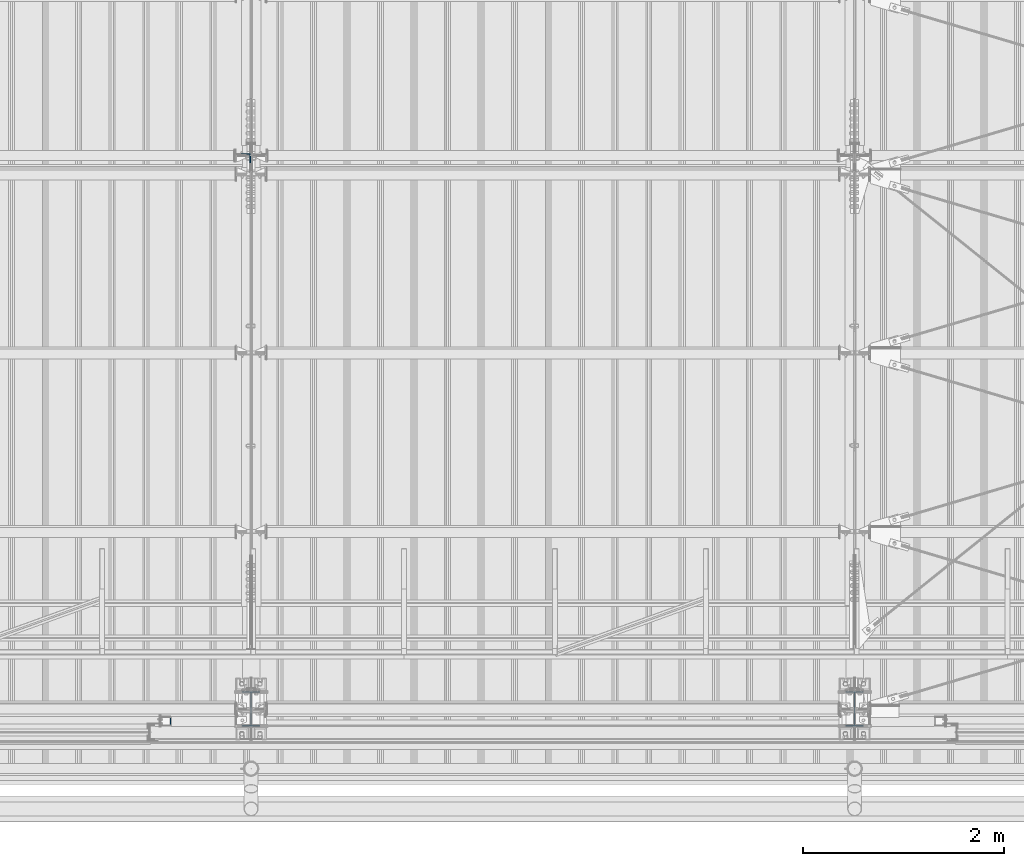
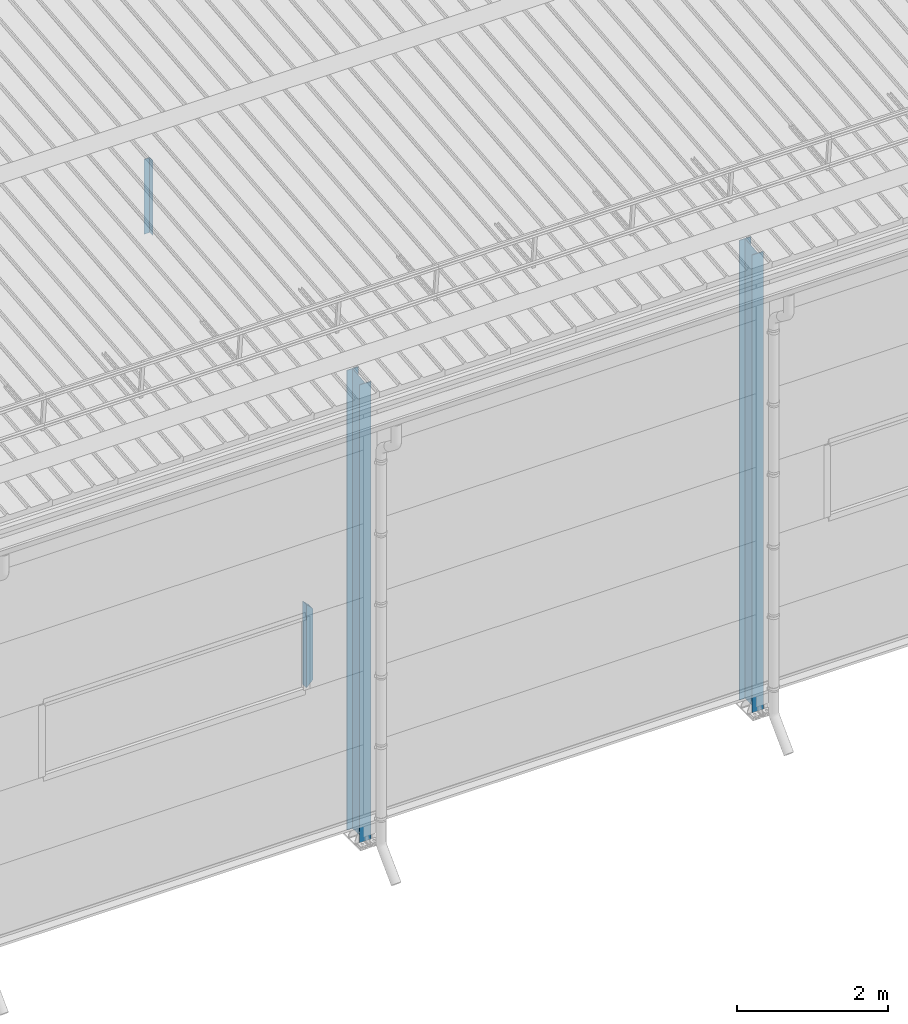
# One storey, part 234 of 709: 4 columns, 4 elements without a shape of their own.
"""IFC4 building model written with IfcOpenShell, lengths in millimetres."""

from ifc_helpers import new_model, si_unit, direction, frame, origin_with_axes, place, context, subcontext, project, spatial, polygons, material, element, aggregate, save


model = new_model("IFC4")

# Units and contexts
model_context = context("Model", 3, precision=0.2, world=origin_with_axes(), true_north=direction((0.0, 1.0)))
body_context = subcontext(model_context, "Body", "Model", "MODEL_VIEW")
ifc_project = project(units=[si_unit("LENGTHUNIT", "METRE", prefix="MILLI"), si_unit("AREAUNIT", "SQUARE_METRE"), si_unit("VOLUMEUNIT", "CUBIC_METRE"), si_unit("MASSUNIT", "GRAM", prefix="KILO"), si_unit("TIMEUNIT", "SECOND"), si_unit("PLANEANGLEUNIT", "RADIAN"), si_unit("SOLIDANGLEUNIT", "STERADIAN"), si_unit("THERMODYNAMICTEMPERATUREUNIT", "DEGREE_CELSIUS"), si_unit("LUMINOUSINTENSITYUNIT", "LUMEN")], contexts=[model_context])

# Site, building, storey
site_placement = place(None, origin_with_axes())
site = spatial("IfcSite", under=ifc_project, at=site_placement, CompositionType="ELEMENT")
building_placement = place(site_placement, origin_with_axes())
building = spatial("IfcBuilding", under=site, at=building_placement, Name="Undefined", CompositionType="ELEMENT")
storey_placement = place(building_placement, origin_with_axes())
storey = spatial("IfcBuildingStorey", under=building, at=storey_placement, Name="Undefined", CompositionType="ELEMENT", Elevation=0.0)

# Assembly, column
assembly_1_placement = place(storey_placement, frame((34000.0, 173.0, -200.0), z_axis=(-1.0, 0.0, 0.0), x_axis=(0.0, 0.0, 1.0)))
assembly_1 = element("IfcElementAssembly", 1, at=assembly_1_placement, inside=storey)
ifc_material_1 = material(Name="C355-5", Category="STEEL")
column_1_placement = place(assembly_1_placement, origin_with_axes())
column_1 = element("IfcColumn", 2, at=column_1_placement, material=ifc_material_1, ObjectType="413", context=body_context, shape_type="Tessellation", body=[
    polygons([(25.0, -173.0, -87.0), (25.0, -164.0, -87.0), (7421.82297, -164.0, -87.0), (7420.92297, -173.0, -87.0), (25.0, -164.0, -3.0), (7421.82297, -164.0, -3.0), (25.0, 164.0, -3.0), (7454.62297, 164.0, -3.0), (25.0, 164.0, -87.0), (7454.62297, 164.0, -87.0), (25.0, 173.0, -87.0), (7455.52297, 173.0, -87.0), (25.0, 173.0, 87.0), (7455.52297, 173.0, 87.0), (25.0, 164.0, 87.0), (7454.62297, 164.0, 87.0), (25.0, 164.0, 3.0), (7454.62297, 164.0, 3.0), (25.0, -164.0, 3.0), (7421.82297, -164.0, 3.0), (25.0, -164.0, 87.0), (7421.82297, -164.0, 87.0), (25.0, -173.0, 87.0), (7420.92297, -173.0, 87.0)], [[[1, 2, 3, 4]], [[2, 5, 6, 3]], [[5, 7, 8, 6]], [[7, 9, 10, 8]], [[9, 11, 12, 10]], [[11, 13, 14, 12]], [[13, 15, 16, 14]], [[15, 17, 18, 16]], [[17, 19, 20, 18]], [[19, 21, 22, 20]], [[21, 23, 24, 22]], [[23, 1, 4, 24]], [[6, 8, 10, 12, 14, 16, 18, 20, 22, 24, 4, 3]], [[23, 21, 19, 17, 15, 13, 11, 9, 7, 5, 2, 1]]], closed=True),
])
aggregate(assembly_1, [column_1])

assembly_2_placement = place(storey_placement, frame((40000.0, 173.0, -200.0), z_axis=(-1.0, 0.0, 0.0), x_axis=(0.0, 0.0, 1.0)))
assembly_2 = element("IfcElementAssembly", 3, at=assembly_2_placement, inside=storey)
column_2_placement = place(assembly_2_placement, origin_with_axes())
column_2 = element("IfcColumn", 4, at=column_2_placement, material=ifc_material_1, ObjectType="413", context=body_context, shape_type="Tessellation", body=[
    polygons([(25.0, -173.0, -87.0), (25.0, -164.0, -87.0), (7421.82297, -164.0, -87.0), (7420.92297, -173.0, -87.0), (25.0, -164.0, -3.0), (7421.82297, -164.0, -3.0), (25.0, 164.0, -3.0), (7454.62297, 164.0, -3.0), (25.0, 164.0, -87.0), (7454.62297, 164.0, -87.0), (25.0, 173.0, -87.0), (7455.52297, 173.0, -87.0), (25.0, 173.0, 87.0), (7455.52297, 173.0, 87.0), (25.0, 164.0, 87.0), (7454.62297, 164.0, 87.0), (25.0, 164.0, 3.0), (7454.62297, 164.0, 3.0), (25.0, -164.0, 3.0), (7421.82297, -164.0, 3.0), (25.0, -164.0, 87.0), (7421.82297, -164.0, 87.0), (25.0, -173.0, 87.0), (7420.92297, -173.0, 87.0)], [[[1, 2, 3, 4]], [[2, 5, 6, 3]], [[5, 7, 8, 6]], [[7, 9, 10, 8]], [[9, 11, 12, 10]], [[11, 13, 14, 12]], [[13, 15, 16, 14]], [[15, 17, 18, 16]], [[17, 19, 20, 18]], [[19, 21, 22, 20]], [[21, 23, 24, 22]], [[23, 1, 4, 24]], [[6, 8, 10, 12, 14, 16, 18, 20, 22, 24, 4, 3]], [[23, 21, 19, 17, 15, 13, 11, 9, 7, 5, 2, 1]]], closed=True),
])
aggregate(assembly_2, [column_2])

assembly_3_placement = place(storey_placement, frame((33949.0, 5648.7, 6024.30002), z_axis=(0.0, -1.0, 0.0), x_axis=(0.0, 0.0, 1.0)))
assembly_3 = element("IfcElementAssembly", 5, at=assembly_3_placement, inside=storey)
ifc_material_2 = material(Name="C345-5", Category="STEEL")
column_3_placement = place(assembly_3_placement, origin_with_axes())
column_3 = element("IfcColumn", 6, at=column_3_placement, material=ifc_material_2, ObjectType="436", context=body_context, shape_type="Tessellation", body=[
    polygons([(185.7, -45.0, -45.0), (185.7, 45.0, -45.0), (1399.0509, 45.0, -45.0), (1399.0509, -45.0, -45.0), (185.7, 45.0, -39.0), (1399.0509, 45.0, -39.0), (185.7, -39.0, -39.0), (1399.0509, -39.0, -39.0), (185.7, -39.0, 45.0), (1399.0509, -39.0, 45.0), (185.7, -45.0, 45.0), (1399.0509, -45.0, 45.0)], [[[1, 2, 3, 4]], [[2, 5, 6, 3]], [[5, 7, 8, 6]], [[7, 9, 10, 8]], [[9, 11, 12, 10]], [[11, 1, 4, 12]], [[6, 8, 10, 12, 4, 3]], [[11, 9, 7, 5, 2, 1]]], closed=True),
])
aggregate(assembly_3, [column_3])

assembly_4_placement = place(storey_placement, frame((33150.0, 50.0, 2600.0), z_axis=(1.0, 0.0, 0.0), x_axis=(0.0, 0.0, 1.0)))
assembly_4 = element("IfcElementAssembly", 7, at=assembly_4_placement, inside=storey)
ifc_material_3 = material(Name="C355", Category="STEEL")
column_4_placement = place(assembly_4_placement, origin_with_axes())
column_4 = element("IfcColumn", 8, at=column_4_placement, material=ifc_material_3, ObjectType="493", context=body_context, shape_type="Tessellation", body=[
    polygons([(10.0, -50.0, -50.0), (10.0, 50.0, -50.0), (1360.0, 50.0, -50.0), (1360.0, -50.0, -50.0), (110.0, -50.0, 50.0), (1260.0, -50.0, 50.0), (110.0, 50.0, 50.0), (1260.0, 50.0, 50.0), (107.0, 47.0, 47.0), (13.0, 47.0, -47.0), (1357.0, 47.0, -47.0), (1263.0, 47.0, 47.0), (107.0, -47.0, 47.0), (1263.0, -47.0, 47.0), (13.0, -47.0, -47.0), (1357.0, -47.0, -47.0)], [[[1, 2, 3, 4]], [[5, 1, 4, 6]], [[7, 5, 6, 8]], [[2, 7, 8, 3]], [[1, 5, 7, 2], [15, 10, 9, 13]], [[9, 10, 11, 12]], [[13, 9, 12, 14]], [[15, 13, 14, 16]], [[10, 15, 16, 11]], [[6, 4, 3, 8], [14, 12, 11, 16]]], closed=True),
])
aggregate(assembly_4, [column_4])

save(model, "model.ifc")
